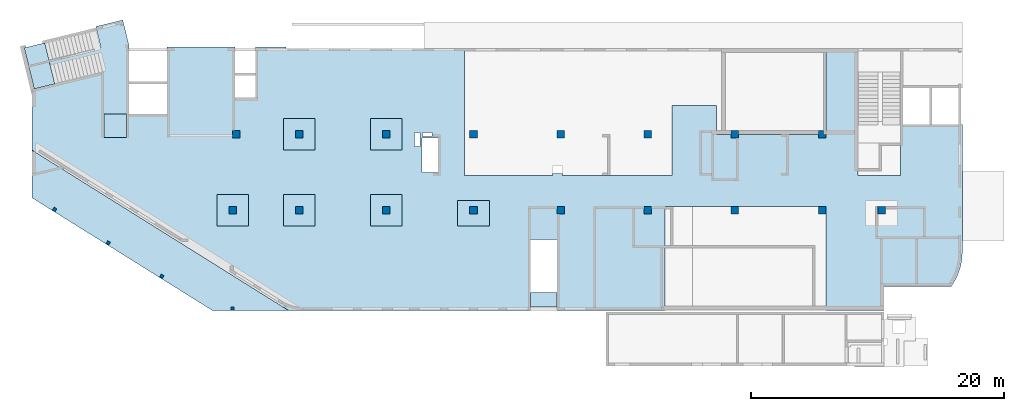
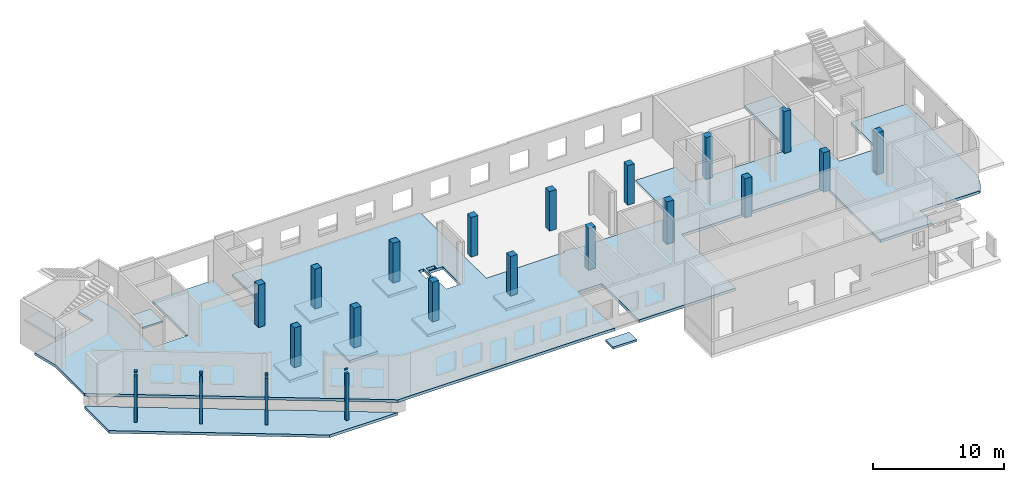
# One storey, part 1 of 8: 21 columns, 11 slabs.
"""IFC4 building model written with IfcOpenShell, lengths in millimetres."""

from ifc_helpers import new_model, entity, si_unit, converted_unit, derived_unit, direction, frame, origin, place, context, subcontext, project, spatial, indexed_curve, outline, extrude, polygons, source, transform, mapped, material, type_object, type_shapes, element, save


model = new_model("IFC4")

# Units and contexts
model_context = context("Model", 3, precision=0.01, world=origin(), true_north=direction((6.12303176911189e-17, 1.0)))
plan_context = context("Plan", 3, precision=0.01, world=origin(), true_north=direction((6.12303176911189e-17, 1.0)))
body_context = subcontext(model_context, "Body", "Model", "MODEL_VIEW")
ifc_project = project(units=[si_unit("LENGTHUNIT", "METRE", prefix="MILLI"), si_unit("AREAUNIT", "SQUARE_METRE"), si_unit("VOLUMEUNIT", "CUBIC_METRE"), converted_unit("PLANEANGLEUNIT", "DEGREE", entity("IfcRatioMeasure", 0.0174532925199433), si_unit("PLANEANGLEUNIT", "RADIAN"), dimensions=[0, 0, 0, 0, 0, 0, 0]), si_unit("MASSUNIT", "GRAM", prefix="KILO"), derived_unit("MASSDENSITYUNIT", [(si_unit("MASSUNIT", "GRAM", prefix="KILO"), 1), (si_unit("LENGTHUNIT", "METRE"), -3)]), derived_unit("MOMENTOFINERTIAUNIT", [(si_unit("LENGTHUNIT", "METRE"), 4)]), si_unit("TIMEUNIT", "SECOND"), si_unit("FREQUENCYUNIT", "HERTZ"), si_unit("THERMODYNAMICTEMPERATUREUNIT", "DEGREE_CELSIUS"), derived_unit("THERMALTRANSMITTANCEUNIT", [(si_unit("MASSUNIT", "GRAM", prefix="KILO"), 1), (si_unit("THERMODYNAMICTEMPERATUREUNIT", "KELVIN"), -1), (si_unit("TIMEUNIT", "SECOND"), -3)]), derived_unit("VOLUMETRICFLOWRATEUNIT", [(si_unit("LENGTHUNIT", "METRE"), 3), (si_unit("TIMEUNIT", "SECOND"), -1)]), derived_unit("MASSFLOWRATEUNIT", [(si_unit("MASSUNIT", "GRAM", prefix="KILO"), 1), (si_unit("TIMEUNIT", "SECOND"), -1)]), derived_unit("ROTATIONALFREQUENCYUNIT", [(si_unit("TIMEUNIT", "SECOND"), -1)]), si_unit("ELECTRICCURRENTUNIT", "AMPERE"), si_unit("ELECTRICVOLTAGEUNIT", "VOLT"), si_unit("POWERUNIT", "WATT"), si_unit("FORCEUNIT", "NEWTON", prefix="KILO"), si_unit("ILLUMINANCEUNIT", "LUX"), si_unit("LUMINOUSFLUXUNIT", "LUMEN"), si_unit("LUMINOUSINTENSITYUNIT", "CANDELA"), derived_unit("USERDEFINED", [(si_unit("MASSUNIT", "GRAM", prefix="KILO"), -1), (si_unit("LENGTHUNIT", "METRE"), -2), (si_unit("TIMEUNIT", "SECOND"), 3), (si_unit("LUMINOUSFLUXUNIT", "LUMEN"), 1)]), derived_unit("LINEARVELOCITYUNIT", [(si_unit("LENGTHUNIT", "METRE"), 1), (si_unit("TIMEUNIT", "SECOND"), -1)]), si_unit("PRESSUREUNIT", "PASCAL"), derived_unit("USERDEFINED", [(si_unit("LENGTHUNIT", "METRE"), -2), (si_unit("MASSUNIT", "GRAM", prefix="KILO"), 1), (si_unit("TIMEUNIT", "SECOND"), -2)]), derived_unit("LINEARFORCEUNIT", [(si_unit("MASSUNIT", "GRAM", prefix="KILO"), 1), (si_unit("LENGTHUNIT", "METRE"), 1), (si_unit("TIMEUNIT", "SECOND"), -2), (si_unit("LENGTHUNIT", "METRE"), -1)]), derived_unit("PLANARFORCEUNIT", [(si_unit("MASSUNIT", "GRAM", prefix="KILO"), 1), (si_unit("LENGTHUNIT", "METRE"), 1), (si_unit("TIMEUNIT", "SECOND"), -2), (si_unit("LENGTHUNIT", "METRE"), -2)])], contexts=[model_context, plan_context])

# Site, building, storey
site_placement = place(None, origin())
site = spatial("IfcSite", under=ifc_project, at=site_placement, CompositionType="ELEMENT")
building_placement = place(site_placement, origin())
building = spatial("IfcBuilding", under=site, at=building_placement, CompositionType="ELEMENT")
storey_placement = place(building_placement, origin())
storey = spatial("IfcBuildingStorey", under=building, at=storey_placement, Name="01", CompositionType="ELEMENT", Elevation=0.0)

# Columns
ifc_material = material()
column_type_1 = type_object("IfcColumnType", PredefinedType="COLUMN", material=ifc_material)
shared_shape_1 = source(origin(), body_context, "Body", "SweptSolid", [
    extrude(outline(indexed_curve([(-300.0, -300.000000000001), (300.0, -300.000000000001), (300.0, 299.999999999999), (-300.0, 299.999999999999), (-300.0, -300.000000000001)], self_intersect=False)), frame((15900.0, 7700.0, -150.0), z_axis=(0.0, 0.0, 1.0), x_axis=(0.0, -1.0, 0.0)), (0.0, 0.0, 1.0), 3700.0),
])
type_shapes(column_type_1, [shared_shape_1])
placement = place(storey_placement, origin())
element("IfcColumn", 1, at=placement, inside=storey, type_object=column_type_1, PredefinedType="COLUMN", context=body_context, shape_type="MappedRepresentation", body=[
    mapped(shared_shape_1, transform((0.0, 0.0, 0.0), scale=1.0)),
])
column_type_2 = type_object("IfcColumnType", PredefinedType="COLUMN", material=ifc_material)
shared_shape_2 = source(origin(), body_context, "Body", "SweptSolid", [
    extrude(outline(indexed_curve([(-300.0, -300.000000000001), (300.0, -300.000000000001), (300.0, 299.999999999997), (-300.0, 300.000000000001), (-300.0, -300.000000000001)], self_intersect=False)), frame((21170.0, 7700.0, -150.0), z_axis=(0.0, 0.0, 1.0), x_axis=(0.0, -1.0, 0.0)), (0.0, 0.0, 1.0), 3700.0),
])
type_shapes(column_type_2, [shared_shape_2])
element("IfcColumn", 2, at=placement, inside=storey, type_object=column_type_2, PredefinedType="COLUMN", context=body_context, shape_type="MappedRepresentation", body=[
    mapped(shared_shape_2, transform((0.0, 0.0, 0.0), scale=1.0)),
])
column_type_3 = type_object("IfcColumnType", PredefinedType="COLUMN", material=ifc_material)
shared_shape_3 = source(origin(), body_context, "Body", "SweptSolid", [
    extrude(outline(indexed_curve([(-300.0, -300.000000000001), (300.0, -300.000000000001), (300.0, 299.999999999997), (-300.0, 300.000000000001), (-300.0, -300.000000000001)], self_intersect=False)), frame((28070.0, 7700.0, -150.0), z_axis=(0.0, 0.0, 1.0), x_axis=(0.0, -1.0, 0.0)), (0.0, 0.0, 1.0), 3700.0),
])
type_shapes(column_type_3, [shared_shape_3])
element("IfcColumn", 3, at=placement, inside=storey, type_object=column_type_3, PredefinedType="COLUMN", context=body_context, shape_type="MappedRepresentation", body=[
    mapped(shared_shape_3, transform((0.0, 0.0, 0.0), scale=1.0)),
])
column_type_4 = type_object("IfcColumnType", PredefinedType="COLUMN", material=ifc_material)
shared_shape_4 = source(origin(), body_context, "Body", "SweptSolid", [
    extrude(outline(indexed_curve([(-300.000000000001, -300.000000000001), (299.999999999999, -300.000000000001), (299.999999999999, 299.999999999997), (-300.000000000001, 300.000000000001), (-300.000000000001, -300.000000000001)], self_intersect=False)), frame((34970.0, 7700.0, -150.0), z_axis=(0.0, 0.0, 1.0), x_axis=(0.0, -1.0, 0.0)), (0.0, 0.0, 1.0), 3700.0),
])
type_shapes(column_type_4, [shared_shape_4])
element("IfcColumn", 4, at=placement, inside=storey, type_object=column_type_4, PredefinedType="COLUMN", context=body_context, shape_type="MappedRepresentation", body=[
    mapped(shared_shape_4, transform((0.0, 0.0, 0.0), scale=1.0)),
])
column_type_5 = type_object("IfcColumnType", PredefinedType="COLUMN", material=ifc_material)
shared_shape_5 = source(origin(), body_context, "Body", "SweptSolid", [
    extrude(outline(indexed_curve([(-300.0, -300.000000000001), (300.0, -300.000000000001), (300.0, 300.000000000001), (-300.0, 300.000000000001), (-300.0, -300.000000000001)], self_intersect=False)), frame((41870.0, 7700.0, -150.0), z_axis=(0.0, 0.0, 1.0), x_axis=(0.0, -1.0, 0.0)), (0.0, 0.0, 1.0), 3900.0),
])
type_shapes(column_type_5, [shared_shape_5])
element("IfcColumn", 5, at=placement, inside=storey, type_object=column_type_5, PredefinedType="COLUMN", context=body_context, shape_type="MappedRepresentation", body=[
    mapped(shared_shape_5, transform((0.0, 0.0, 0.0), scale=1.0)),
])
column_type_6 = type_object("IfcColumnType", PredefinedType="COLUMN", material=ifc_material)
shared_shape_6 = source(origin(), body_context, "Body", "SweptSolid", [
    extrude(outline(indexed_curve([(-300.0, -300.000000000001), (300.0, -300.000000000001), (300.0, 300.000000000001), (-300.0, 300.000000000001), (-300.0, -300.000000000001)], self_intersect=False)), frame((48770.0, 7700.0, -150.0), z_axis=(0.0, 0.0, 1.0), x_axis=(0.0, -1.0, 0.0)), (0.0, 0.0, 1.0), 3950.0),
])
type_shapes(column_type_6, [shared_shape_6])
element("IfcColumn", 6, at=placement, inside=storey, type_object=column_type_6, PredefinedType="COLUMN", context=body_context, shape_type="MappedRepresentation", body=[
    mapped(shared_shape_6, transform((0.0, 0.0, 0.0), scale=1.0)),
])
column_type_7 = type_object("IfcColumnType", PredefinedType="COLUMN", material=ifc_material)
shared_shape_7 = source(origin(), body_context, "Body", "SweptSolid", [
    extrude(outline(indexed_curve([(-300.0, -300.000000000001), (300.0, -300.000000000001), (300.0, 300.000000000001), (-300.0, 300.000000000001), (-300.0, -300.000000000001)], self_intersect=False)), frame((55670.0, 7700.0, -150.0), z_axis=(0.0, 0.0, 1.0), x_axis=(0.0, -1.0, 0.0)), (0.0, 0.0, 1.0), 3700.0),
])
type_shapes(column_type_7, [shared_shape_7])
element("IfcColumn", 7, at=placement, inside=storey, type_object=column_type_7, PredefinedType="COLUMN", context=body_context, shape_type="MappedRepresentation", body=[
    mapped(shared_shape_7, transform((0.0, 0.0, 0.0), scale=1.0)),
])
column_type_8 = type_object("IfcColumnType", PredefinedType="COLUMN", material=ifc_material)
shared_shape_8 = source(origin(), body_context, "Body", "SweptSolid", [
    extrude(outline(indexed_curve([(-299.999999999999, -300.000000000001), (300.000000000001, -300.000000000001), (300.000000000001, 300.000000000001), (-299.999999999999, 300.000000000001), (-299.999999999999, -300.000000000001)], self_intersect=False)), frame((62570.0, 7700.0, -150.0), z_axis=(0.0, 0.0, 1.0), x_axis=(0.0, -1.0, 0.0)), (0.0, 0.0, 1.0), 3700.0),
])
type_shapes(column_type_8, [shared_shape_8])
element("IfcColumn", 8, at=placement, inside=storey, type_object=column_type_8, PredefinedType="COLUMN", context=body_context, shape_type="MappedRepresentation", body=[
    mapped(shared_shape_8, transform((0.0, 0.0, 0.0), scale=1.0)),
])
column_type_9 = type_object("IfcColumnType", PredefinedType="COLUMN", material=ifc_material)
shared_shape_9 = source(origin(), body_context, "Body", "Tessellation", [
    polygons([(600.000000000002, 600.0, 0.0), (600.000000000002, 1.08286712929839e-12, 0.0), (0.0, 1.08286712929839e-12, 0.0), (0.0, 600.0, 0.0), (600.000000000002, 600.0, 150.0), (600.000000000002, 600.0, 3900.0), (600.000000000002, 1.08286712929839e-12, 3900.0), (24.9997314451952, 1.08286712929839e-12, 3900.0), (24.9997314451952, 1.08286712929839e-12, 150.0), (0.0, 1.08286712929839e-12, 150.0), (0.0, 600.0, 150.0), (24.9997314451952, 600.0, 150.0), (24.9997314451952, 600.0, 3900.0)], [[[1, 2, 3, 4]], [[2, 1, 5, 6, 7]], [[3, 2, 7, 8, 9, 10]], [[4, 3, 10, 11]], [[1, 4, 11, 12, 13, 6, 5]], [[7, 6, 13, 8]], [[12, 9, 8, 13]], [[9, 12, 11, 10]]], closed=True),
])
type_shapes(column_type_9, [shared_shape_9])
column_9_placement = place(storey_placement, frame((66970.0, 7400.0, -150.0)))
element("IfcColumn", 9, at=column_9_placement, inside=storey, type_object=column_type_9, material=ifc_material, PredefinedType="COLUMN", context=body_context, shape_type="MappedRepresentation", body=[
    mapped(shared_shape_9, transform((0.0, 0.0, 0.0), scale=1.0)),
])
column_type_10 = type_object("IfcColumnType", PredefinedType="COLUMN", material=ifc_material)
shared_shape_10 = source(origin(), body_context, "Body", "SweptSolid", [
    extrude(outline(indexed_curve([(-299.999999999999, -333.333333333327), (300.000000000001, -333.333333333327), (299.999999999999, 266.666666666675), (-4.33146851719357e-12, 266.666666666675), (-2.16573425859679e-12, 66.6666666666688), (-299.999999999999, 66.6666666666688), (-299.999999999999, -333.333333333327)], self_intersect=False)), frame((62603.33, 13700.0, -150.0), z_axis=(0.0, 0.0, 1.0), x_axis=(0.0, -1.0, 0.0)), (0.0, 0.0, 1.0), 3900.0),
])
type_shapes(column_type_10, [shared_shape_10])
element("IfcColumn", 10, at=placement, inside=storey, type_object=column_type_10, PredefinedType="COLUMN", context=body_context, shape_type="MappedRepresentation", body=[
    mapped(shared_shape_10, transform((0.0, 0.0, 0.0), scale=1.0)),
])
column_type_11 = type_object("IfcColumnType", PredefinedType="COLUMN", material=ifc_material)
shared_shape_11 = source(origin(), body_context, "Body", "SweptSolid", [
    extrude(outline(indexed_curve([(-299.999999999997, -300.000000000001), (300.000000000003, -300.000000000001), (300.000000000001, 300.000000000001), (-299.999999999999, 300.000000000001), (-299.999999999997, -300.000000000001)], self_intersect=False)), frame((55670.0, 13700.0, -150.0), z_axis=(0.0, 0.0, 1.0), x_axis=(0.0, -1.0, 0.0)), (0.0, 0.0, 1.0), 3900.0),
])
type_shapes(column_type_11, [shared_shape_11])
element("IfcColumn", 11, at=placement, inside=storey, type_object=column_type_11, PredefinedType="COLUMN", context=body_context, shape_type="MappedRepresentation", body=[
    mapped(shared_shape_11, transform((0.0, 0.0, 0.0), scale=1.0)),
])
column_type_12 = type_object("IfcColumnType", PredefinedType="COLUMN", material=ifc_material)
shared_shape_12 = source(origin(), body_context, "Body", "SweptSolid", [
    extrude(outline(indexed_curve([(-299.999999999999, -300.000000000001), (300.000000000001, -300.000000000001), (299.999999999999, 300.000000000001), (-300.000000000001, 300.000000000001), (-299.999999999999, -300.000000000001)], self_intersect=False)), frame((48770.0, 13700.0, -150.0), z_axis=(0.0, 0.0, 1.0), x_axis=(0.0, -1.0, 0.0)), (0.0, 0.0, 1.0), 3700.0),
])
type_shapes(column_type_12, [shared_shape_12])
element("IfcColumn", 12, at=placement, inside=storey, type_object=column_type_12, PredefinedType="COLUMN", context=body_context, shape_type="MappedRepresentation", body=[
    mapped(shared_shape_12, transform((0.0, 0.0, 0.0), scale=1.0)),
])
column_type_13 = type_object("IfcColumnType", PredefinedType="COLUMN", material=ifc_material)
shared_shape_13 = source(origin(), body_context, "Body", "SweptSolid", [
    extrude(outline(indexed_curve([(-300.000000000001, -300.000000000001), (299.999999999999, -300.000000000001), (299.999999999997, 300.000000000001), (-300.000000000003, 300.000000000001), (-300.000000000001, -300.000000000001)], self_intersect=False)), frame((41870.0, 13700.0, -150.0), z_axis=(0.0, 0.0, 1.0), x_axis=(0.0, -1.0, 0.0)), (0.0, 0.0, 1.0), 3700.0),
])
type_shapes(column_type_13, [shared_shape_13])
element("IfcColumn", 13, at=placement, inside=storey, type_object=column_type_13, PredefinedType="COLUMN", context=body_context, shape_type="MappedRepresentation", body=[
    mapped(shared_shape_13, transform((0.0, 0.0, 0.0), scale=1.0)),
])
column_type_14 = type_object("IfcColumnType", PredefinedType="COLUMN", material=ifc_material)
shared_shape_14 = source(origin(), body_context, "Body", "SweptSolid", [
    extrude(outline(indexed_curve([(-299.999999999999, -300.000000000001), (300.000000000001, -300.000000000001), (299.999999999999, 299.999999999997), (-300.000000000001, 300.000000000001), (-299.999999999999, -300.000000000001)], self_intersect=False)), frame((34970.0, 13700.0, -150.0), z_axis=(0.0, 0.0, 1.0), x_axis=(0.0, -1.0, 0.0)), (0.0, 0.0, 1.0), 3700.0),
])
type_shapes(column_type_14, [shared_shape_14])
element("IfcColumn", 14, at=placement, inside=storey, type_object=column_type_14, PredefinedType="COLUMN", context=body_context, shape_type="MappedRepresentation", body=[
    mapped(shared_shape_14, transform((0.0, 0.0, 0.0), scale=1.0)),
])
column_type_15 = type_object("IfcColumnType", PredefinedType="COLUMN", material=ifc_material)
shared_shape_15 = source(origin(), body_context, "Body", "SweptSolid", [
    extrude(outline(indexed_curve([(-299.999999999997, -300.000000000001), (300.000000000003, -300.000000000001), (300.000000000001, 299.999999999997), (-299.999999999999, 300.000000000001), (-299.999999999997, -300.000000000001)], self_intersect=False)), frame((28070.0, 13700.0, -150.0), z_axis=(0.0, 0.0, 1.0), x_axis=(0.0, -1.0, 0.0)), (0.0, 0.0, 1.0), 3700.0),
])
type_shapes(column_type_15, [shared_shape_15])
element("IfcColumn", 15, at=placement, inside=storey, type_object=column_type_15, PredefinedType="COLUMN", context=body_context, shape_type="MappedRepresentation", body=[
    mapped(shared_shape_15, transform((0.0, 0.0, 0.0), scale=1.0)),
])
column_type_16 = type_object("IfcColumnType", PredefinedType="COLUMN", material=ifc_material)
shared_shape_16 = source(origin(), body_context, "Body", "SweptSolid", [
    extrude(outline(indexed_curve([(-299.999999999999, -300.000000000001), (300.000000000001, -300.000000000001), (299.999999999999, 299.999999999997), (-300.000000000001, 300.000000000001), (-299.999999999999, -300.000000000001)], self_intersect=False)), frame((21170.0, 13700.0, -150.0), z_axis=(0.0, 0.0, 1.0), x_axis=(0.0, -1.0, 0.0)), (0.0, 0.0, 1.0), 3700.0),
])
type_shapes(column_type_16, [shared_shape_16])
element("IfcColumn", 16, at=placement, inside=storey, type_object=column_type_16, PredefinedType="COLUMN", context=body_context, shape_type="MappedRepresentation", body=[
    mapped(shared_shape_16, transform((0.0, 0.0, 0.0), scale=1.0)),
])
column_type_17 = type_object("IfcColumnType", PredefinedType="COLUMN", material=ifc_material)
shared_shape_17 = source(origin(), body_context, "Body", "SweptSolid", [
    extrude(outline(indexed_curve([(-300.000000000001, -300.000000000001), (299.999999999999, -300.000000000001), (299.999999999999, 299.999999999999), (-300.000000000001, 299.999999999999), (-300.000000000001, -300.000000000001)], self_intersect=False)), frame((16200.0, 13700.0, -150.0), z_axis=(0.0, 0.0, 1.0), x_axis=(0.0, -1.0, 0.0)), (0.0, 0.0, 1.0), 3950.0),
])
type_shapes(column_type_17, [shared_shape_17])
element("IfcColumn", 17, at=placement, inside=storey, type_object=column_type_17, PredefinedType="COLUMN", context=body_context, shape_type="MappedRepresentation", body=[
    mapped(shared_shape_17, transform((0.0, 0.0, 0.0), scale=1.0)),
])
column_type_18 = type_object("IfcColumnType", PredefinedType="COLUMN", material=ifc_material)
shared_shape_18 = source(origin(), body_context, "Body", "SweptSolid", [
    extrude(outline(indexed_curve([(-125.0, -125.0), (125.0, -125.0), (125.0, 125.0), (-125.0, 125.0), (-125.0, -125.0)], self_intersect=False)), frame((15900.0, -75.0, -550.0), z_axis=(0.0, 0.0, 1.0), x_axis=(0.0, -1.0, 0.0)), (0.0, 0.0, 1.0), 4350.0),
    extrude(outline(indexed_curve([(-25.0000000000073, -125.0), (25.000000000007, -125.0), (25.0000000000077, 125.0), (-25.0000000000073, 125.0), (-25.0000000000073, -125.0)], self_intersect=False)), frame((15900.0, 25.0, 4050.0), z_axis=(0.0, 0.0, 1.0), x_axis=(0.0, -1.0, 0.0)), (0.0, 0.0, 1.0), 150.0),
])
type_shapes(column_type_18, [shared_shape_18])
element("IfcColumn", 18, at=placement, inside=storey, type_object=column_type_18, PredefinedType="COLUMN", context=body_context, shape_type="MappedRepresentation", body=[
    mapped(shared_shape_18, transform((0.0, 0.0, 0.0), scale=1.0)),
])
column_type_19 = type_object("IfcColumnType", PredefinedType="COLUMN", material=ifc_material)
shared_shape_19 = source(origin(), body_context, "Body", "SweptSolid", [
    extrude(outline(indexed_curve([(-125.0, -125.0), (125.0, -125.0), (125.0, 125.0), (-125.0, 125.0), (-125.0, -125.0)], self_intersect=False)), frame((10294.08, 2463.18, -550.0), z_axis=(0.0, 0.0, 1.0), x_axis=(-0.84805274377757, 0.529911826412031, 0.0)), (0.0, 0.0, 1.0), 4350.0),
    extrude(outline(indexed_curve([(-125.0, -125.0), (125.0, -125.0), (125.0, 125.0), (-125.0, 125.0), (-125.0, -125.0)], self_intersect=False)), frame((10294.08, 2463.18, 4050.0), z_axis=(0.0, 0.0, 1.0), x_axis=(-0.84805274377757, 0.529911826412031, 0.0)), (0.0, 0.0, 1.0), 150.0),
])
type_shapes(column_type_19, [shared_shape_19])
element("IfcColumn", 19, at=placement, inside=storey, type_object=column_type_19, PredefinedType="COLUMN", context=body_context, shape_type="MappedRepresentation", body=[
    mapped(shared_shape_19, transform((0.0, 0.0, 0.0), scale=1.0)),
])
column_type_20 = type_object("IfcColumnType", PredefinedType="COLUMN", material=ifc_material)
shared_shape_20 = source(origin(), body_context, "Body", "SweptSolid", [
    extrude(outline(indexed_curve([(-125.0, -125.0), (125.0, -125.0), (125.0, 125.0), (-125.0, 125.0), (-125.0, -125.0)], self_intersect=False)), frame((6053.81, 5112.74, -550.0), z_axis=(0.0, 0.0, 1.0), x_axis=(-0.848052743777571, 0.52991182641203, 0.0)), (0.0, 0.0, 1.0), 4350.0),
    extrude(outline(indexed_curve([(-125.0, -125.0), (125.0, -125.0), (125.0, 125.0), (-125.0, 125.0), (-125.0, -125.0)], self_intersect=False)), frame((6053.81, 5112.74, 4050.0), z_axis=(0.0, 0.0, 1.0), x_axis=(-0.848052743777571, 0.52991182641203, 0.0)), (0.0, 0.0, 1.0), 150.0),
])
type_shapes(column_type_20, [shared_shape_20])
element("IfcColumn", 20, at=placement, inside=storey, type_object=column_type_20, PredefinedType="COLUMN", context=body_context, shape_type="MappedRepresentation", body=[
    mapped(shared_shape_20, transform((0.0, 0.0, 0.0), scale=1.0)),
])
column_type_21 = type_object("IfcColumnType", PredefinedType="COLUMN", material=ifc_material)
shared_shape_21 = source(origin(), body_context, "Body", "SweptSolid", [
    extrude(outline(indexed_curve([(-125.0, -125.0), (125.0, -125.0), (125.0, 125.0), (-125.0, 125.000000000001), (-125.0, -125.0)], self_intersect=False)), frame((1813.55, 7762.3, -550.0), z_axis=(0.0, 0.0, 1.0), x_axis=(-0.848052743777571, 0.52991182641203, 0.0)), (0.0, 0.0, 1.0), 4350.0),
    extrude(outline(indexed_curve([(-125.0, -125.0), (125.0, -125.0), (125.0, 125.0), (-125.0, 125.000000000001), (-125.0, -125.0)], self_intersect=False)), frame((1813.55, 7762.3, 4050.0), z_axis=(0.0, 0.0, 1.0), x_axis=(-0.848052743777571, 0.52991182641203, 0.0)), (0.0, 0.0, 1.0), 150.0),
])
type_shapes(column_type_21, [shared_shape_21])
element("IfcColumn", 21, at=placement, inside=storey, type_object=column_type_21, PredefinedType="COLUMN", context=body_context, shape_type="MappedRepresentation", body=[
    mapped(shared_shape_21, transform((0.0, 0.0, 0.0), scale=1.0)),
])

# Slabs
slab_type_1 = type_object("IfcSlabType", Name=":ADSK_ 25_250", PredefinedType="FLOOR", material=ifc_material)
element("IfcSlab", 22, at=placement, inside=storey, type_object=slab_type_1, material=ifc_material, Name=":ADSK_ 25_250", ObjectType=":ADSK_ 25_250", PredefinedType="FLOOR", context=body_context, shape_type="SweptSolid", body=[
    extrude(outline(indexed_curve([(-4025.15643417913, -37177.3291465367), (351.455717432071, -37177.3291465367), (13063.9605678396, -16832.6716368716), (13063.9605678396, 2292.67085346331), (7438.9605678395, 2292.67085346332), (7438.9605678395, 4392.67085346331), (13063.9605678396, 4392.67085346332), (13063.9605678396, 12942.6708534633), (4813.96056783958, 12942.6708534633), (4813.9605678396, 25692.6708534633), (13063.9605678396, 25692.6708534633), (13063.9605678396, 30292.6708534633), (11168.9605678397, 30292.6708534633), (11168.9605678397, 35600.554123733), (10925.2178127369, 35765.5271370395), (10671.6270838178, 35914.9204701934), (10409.1828450559, 36048.1482725668), (10138.9142797407, 36164.6880871666), (9861.88125450251, 36264.0828994655), (9579.17016301315, 36345.9429295988), (9291.88966565861, 36409.9471608985), (9001.16634189293, 36455.8445987701), (8708.14027232157, 36483.4552549756), (8413.96056783968, 36492.6708534633), (-1656.03943216033, 36492.6708534633), (-1656.03943216033, 31592.6708534633), (2388.96056783964, 31592.6708534633), (2388.96056783965, 28252.6708534633), (-7686.04007152704, 28252.6708534633), (-7686.04007152704, 25692.6708534633), (-586.039432160554, 25692.6708534633), (-586.039432160553, 25092.6708534633), (-886.03943216039, 25092.6708534633), (-886.039432160402, 18792.6708534633), (-586.039432160566, 18792.6708534633), (-586.039432160567, 18192.6708534633), (-886.039432160399, 18192.6708534633), (-886.039432160403, 17042.6708534633), (-3186.03943216043, 17042.6708534633), (-3186.03943216044, 13492.6708534633), (2388.96056783952, 13492.6708534633), (2388.9605678395, 4857.6708534633), (2228.96056783951, 4857.67085346331), (2228.96056783951, 4027.67085346331), (2388.9605678395, 4027.67085346332), (2388.96056783949, -2907.32914653667), (-7686.04007152708, -2907.32914653666), (-7686.0400715271, -17067.3291465367), (-7786.0400715271, -17067.3291465367), (-7786.0400715271, -19452.3291465367), (-3686.0400715271, -19452.3291465367), (-3686.0400715271, -21077.3291465367), (-7786.03943216063, -21077.3291465367), (-7786.03943216064, -26477.3291465367), (-2386.04007152711, -26477.3291465367), (-2386.04007152711, -29477.3291465367), (-7905.81506587364, -29477.3291465367), (-9940.31254426151, -29973.2594314532), (-9419.29513968276, -32110.6739593644), (-7748.22559967943, -31703.333079421), (-6279.90570125012, -37726.9481351627), (-4025.15643417913, -37177.3291465367)], self_intersect=False), holes=[indexed_curve([(88.9597941956961, -6427.32941509152), (88.9597941956991, -6887.32941509151), (-1051.04020580432, -6887.3294150915), (-1051.04020580432, -6427.32941509151), (88.9597941956961, -6427.32941509152)], self_intersect=False), indexed_curve([(-706.040205804316, -6247.32941509151), (-1026.04020580432, -6247.32941509151), (-1026.04020580432, -5487.32941509151), (-706.040205804318, -5487.32941509151), (-706.040205804316, -6247.32941509151)], self_intersect=False), indexed_curve([(-586.040205804311, -5007.3291465367), (2123.95979419568, -5007.3291465367), (2123.95979419568, -6287.3294150915), (-586.040205804309, -6287.32941509151), (-586.040205804311, -5007.3291465367)], self_intersect=False)]), frame((37177.33, 12813.96, -400.0), z_axis=(0.0, 0.0, 1.0), x_axis=(0.0, -1.0, 0.0)), (0.0, 0.0, 1.0), 250.0),
])
slab_type_2 = type_object("IfcSlabType", Name=":ADSK_ 25_250", PredefinedType="FLOOR", material=ifc_material)
element("IfcSlab", 23, at=placement, inside=storey, type_object=slab_type_2, material=ifc_material, Name=":ADSK_ 25_250", ObjectType=":ADSK_ 25_250", PredefinedType="FLOOR", context=body_context, shape_type="SweptSolid", body=[
    extrude(outline(indexed_curve([(3526.23976666387, -8662.64363341016), (7299.58997805036, -8662.64363341016), (-5412.91487235712, 11682.0138762549), (-5412.91487235712, 5643.27339056538), (3526.23976666387, -8662.64363341016)], self_intersect=False)), frame((8662.64, 5162.91, -1320.0), z_axis=(0.0, 0.0, -1.0), x_axis=(0.0, 1.0, 0.0)), (0.0, 0.0, 1.0), 250.0),
])
slab_type_3 = type_object("IfcSlabType", Name=":ADSK_ 25_250", PredefinedType="FLOOR", material=ifc_material)
element("IfcSlab", 24, at=placement, inside=storey, type_object=slab_type_3, material=ifc_material, Name=":ADSK_ 25_250", ObjectType=":ADSK_ 25_250", PredefinedType="FLOOR", context=body_context, shape_type="SweptSolid", body=[
    extrude(outline(indexed_curve([(-1250.0, -1250.0), (1250.0, -1250.0), (1250.0, 1250.0), (-1250.0, 1250.0), (-1250.0, -1250.0)], self_intersect=False)), frame((15900.0, 7700.0, -400.0), z_axis=(0.0, 0.0, -1.0), x_axis=(0.0, 1.0, 0.0)), (0.0, 0.0, 1.0), 250.0),
])
slab_type_4 = type_object("IfcSlabType", Name=":ADSK_ 25_250", PredefinedType="FLOOR", material=ifc_material)
element("IfcSlab", 25, at=placement, inside=storey, type_object=slab_type_4, material=ifc_material, Name=":ADSK_ 25_250", ObjectType=":ADSK_ 25_250", PredefinedType="FLOOR", context=body_context, shape_type="SweptSolid", body=[
    extrude(outline(indexed_curve([(-1250.0, -1250.0), (1250.0, -1250.0), (1250.0, 1250.00000000001), (-1250.0, 1250.0), (-1250.0, -1250.0)], self_intersect=False)), frame((21170.0, 7700.0, -400.0), z_axis=(0.0, 0.0, -1.0), x_axis=(0.0, 1.0, 0.0)), (0.0, 0.0, 1.0), 250.0),
])
slab_type_5 = type_object("IfcSlabType", Name=":ADSK_ 25_250", PredefinedType="FLOOR", material=ifc_material)
element("IfcSlab", 26, at=placement, inside=storey, type_object=slab_type_5, material=ifc_material, Name=":ADSK_ 25_250", ObjectType=":ADSK_ 25_250", PredefinedType="FLOOR", context=body_context, shape_type="SweptSolid", body=[
    extrude(outline(indexed_curve([(-1250.0, -1250.0), (1250.0, -1250.0), (1250.0, 1250.00000000001), (-1250.0, 1250.0), (-1250.0, -1250.0)], self_intersect=False)), frame((28070.0, 7700.0, -400.0), z_axis=(0.0, 0.0, -1.0), x_axis=(0.0, 1.0, 0.0)), (0.0, 0.0, 1.0), 250.0),
])
slab_type_6 = type_object("IfcSlabType", Name=":ADSK_ 25_250", PredefinedType="FLOOR", material=ifc_material)
element("IfcSlab", 27, at=placement, inside=storey, type_object=slab_type_6, material=ifc_material, Name=":ADSK_ 25_250", ObjectType=":ADSK_ 25_250", PredefinedType="FLOOR", context=body_context, shape_type="SweptSolid", body=[
    extrude(outline(indexed_curve([(-999.999999999959, -1250.0), (999.99999999996, -1250.0), (999.99999999996, 1250.00000000001), (-999.999999999959, 1250.0), (-999.999999999959, -1250.0)], self_intersect=False)), frame((34970.0, 7450.0, -400.0), z_axis=(0.0, 0.0, -1.0), x_axis=(0.0, 1.0, 0.0)), (0.0, 0.0, 1.0), 250.0),
])
slab_type_7 = type_object("IfcSlabType", Name=":ADSK_ 25_250", PredefinedType="FLOOR", material=ifc_material)
element("IfcSlab", 28, at=placement, inside=storey, type_object=slab_type_7, material=ifc_material, Name=":ADSK_ 25_250", ObjectType=":ADSK_ 25_250", PredefinedType="FLOOR", context=body_context, shape_type="SweptSolid", body=[
    extrude(outline(indexed_curve([(-1250.0, -1250.0), (1250.0, -1250.0), (1250.0, 1250.00000000001), (-1250.0, 1250.0), (-1250.0, -1250.0)], self_intersect=False)), frame((21170.0, 13700.0, -400.0), z_axis=(0.0, 0.0, -1.0), x_axis=(0.0, 1.0, 0.0)), (0.0, 0.0, 1.0), 250.0),
])
slab_type_8 = type_object("IfcSlabType", Name=":ADSK_ 25_250", PredefinedType="FLOOR", material=ifc_material)
element("IfcSlab", 29, at=placement, inside=storey, type_object=slab_type_8, material=ifc_material, Name=":ADSK_ 25_250", ObjectType=":ADSK_ 25_250", PredefinedType="FLOOR", context=body_context, shape_type="SweptSolid", body=[
    extrude(outline(indexed_curve([(-1250.0, -1250.0), (1250.0, -1250.0), (1250.0, 1250.00000000001), (-1250.0, 1250.0), (-1250.0, -1250.0)], self_intersect=False)), frame((28070.0, 13700.0, -400.0), z_axis=(0.0, 0.0, -1.0), x_axis=(0.0, 1.0, 0.0)), (0.0, 0.0, 1.0), 250.0),
])
slab_type_9 = type_object("IfcSlabType", Name=":ADSK_ 25_150", PredefinedType="FLOOR", material=ifc_material)
element("IfcSlab", 30, at=placement, inside=storey, type_object=slab_type_9, material=ifc_material, Name=":ADSK_ 25_150", ObjectType=":ADSK_ 25_150", PredefinedType="FLOOR", context=body_context, shape_type="SweptSolid", body=[
    extrude(outline(indexed_curve([(-925.000000000002, -900.000000000003), (924.999999999998, -900.000000000003), (924.999999999998, 900.000000000002), (-925.000000000002, 900.000000000002), (-925.000000000002, -900.000000000003)], self_intersect=False)), frame((6600.0, 14375.0, 3400.0), z_axis=(0.0, 0.0, -1.0), x_axis=(0.0, 1.0, 0.0)), (0.0, 0.0, 1.0), 150.0),
])
slab_type_10 = type_object("IfcSlabType", Name=":ADSK_ 25_200", PredefinedType="FLOOR", material=ifc_material)
element("IfcSlab", 31, at=placement, inside=storey, type_object=slab_type_10, material=ifc_material, Name=":ADSK_ 25_200", ObjectType=":ADSK_ 25_200", PredefinedType="FLOOR", context=body_context, shape_type="SweptSolid", body=[
    extrude(outline(indexed_curve([(-835.0, -1670.00000000002), (835.0, -1670.00000000002), (834.999999999999, 1670.00000000002), (-835.000000000001, 1670.00000000002), (-835.0, -1670.00000000002)], self_intersect=False)), frame((612.3, 19119.78, 2070.0), z_axis=(0.0, 0.0, -1.0), x_axis=(0.971552058141474, 0.236826092990333, 0.0)), (0.0, 0.0, 1.0), 200.0),
])
slab_type_11 = type_object("IfcSlabType", Name=":ADSK_ 25_200", PredefinedType="FLOOR", material=ifc_material)
element("IfcSlab", 32, at=placement, inside=storey, type_object=slab_type_11, material=ifc_material, Name=":ADSK_ 25_200", ObjectType=":ADSK_ 25_200", PredefinedType="FLOOR", context=body_context, shape_type="SweptSolid", body=[
    extrude(outline(indexed_curve([(-575.0, -1050.0), (575.0, -1050.0), (575.0, 1050.0), (-575.0, 1050.0), (-575.0, -1050.0)], self_intersect=False)), frame((40520.0, 625.0, -2130.0), z_axis=(0.0, 0.0, -1.0), x_axis=(0.0, 1.0, 0.0)), (0.0, 0.0, 1.0), 200.0),
])

save(model, "model.ifc")
